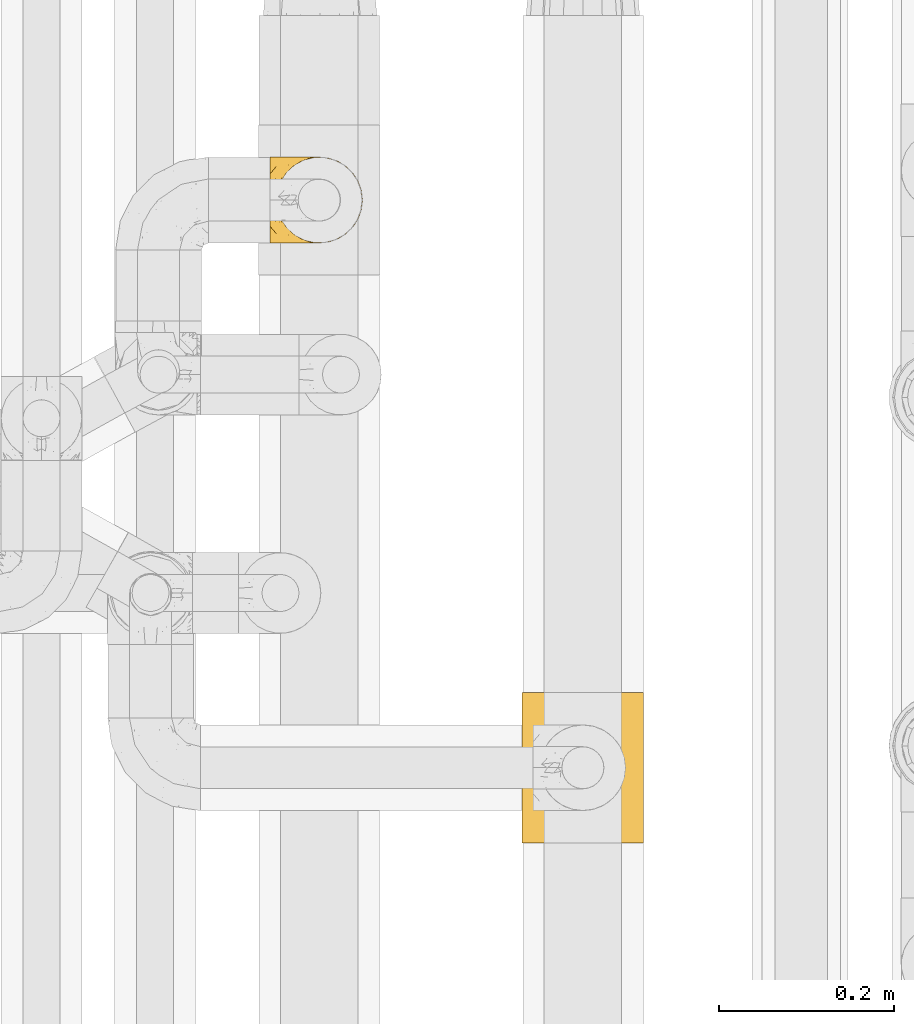
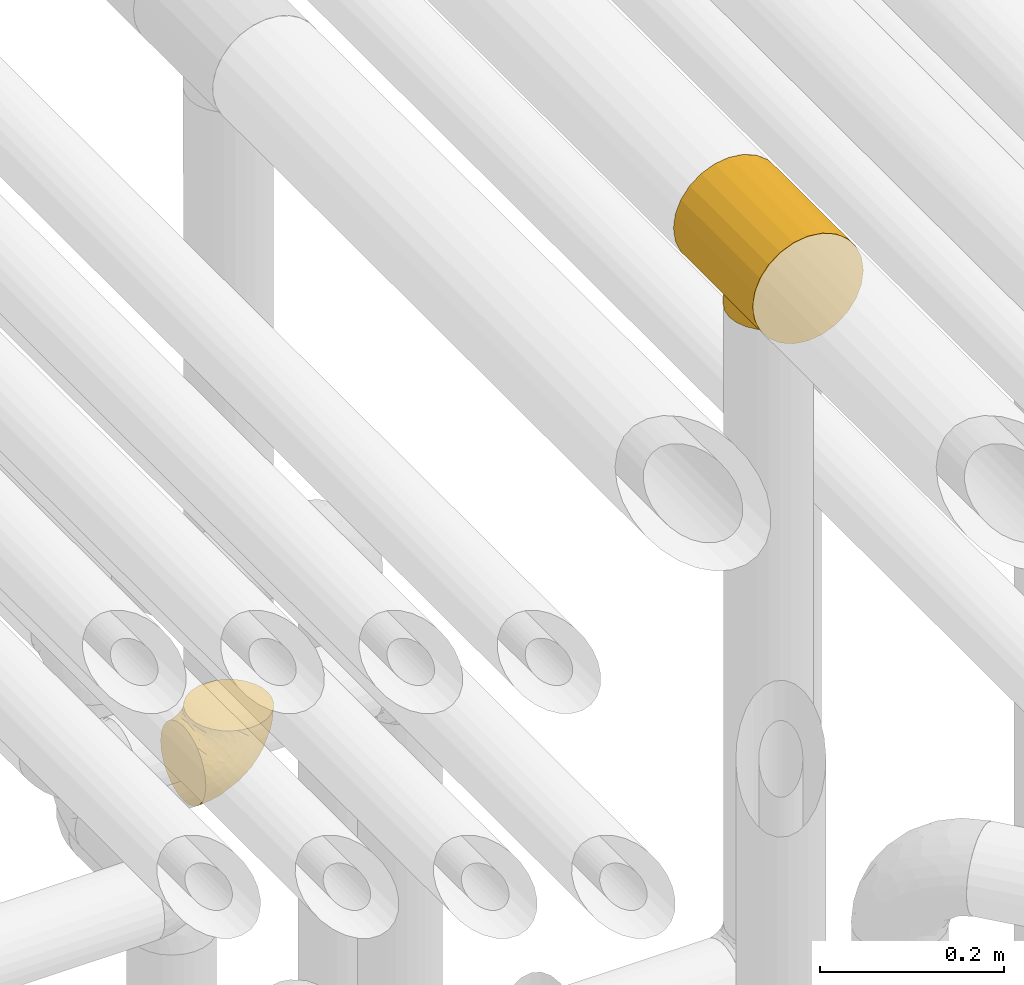
# One storey, part 222 of 827: 2 coverings.
"""IFC2X3 building model written with IfcOpenShell, lengths in millimetres."""

from ifc_helpers import new_model, entity, si_unit, converted_unit, derived_unit, direction, frame, origin, place, context, subcontext, project, spatial, faceted_brep, element, save


model = new_model("IFC2X3")

# Units and contexts
model_context = context("Model", 3, precision=0.01, world=origin(), true_north=direction((6.12303176911189e-17, 1.0)))
body_context = subcontext(model_context, "Body", "Model", "MODEL_VIEW")
ifc_project = project(units=[si_unit("LENGTHUNIT", "METRE", prefix="MILLI"), si_unit("AREAUNIT", "SQUARE_METRE"), si_unit("VOLUMEUNIT", "CUBIC_METRE"), converted_unit("PLANEANGLEUNIT", "DEGREE", entity("IfcRatioMeasure", 0.0174532925199433), si_unit("PLANEANGLEUNIT", "RADIAN"), dimensions=[0, 0, 0, 0, 0, 0, 0]), si_unit("MASSUNIT", "GRAM", prefix="KILO"), derived_unit("MASSDENSITYUNIT", [(si_unit("MASSUNIT", "GRAM", prefix="KILO"), 1), (si_unit("LENGTHUNIT", "METRE"), -3)]), derived_unit("MOMENTOFINERTIAUNIT", [(si_unit("LENGTHUNIT", "METRE"), 4)]), si_unit("TIMEUNIT", "SECOND"), si_unit("FREQUENCYUNIT", "HERTZ"), si_unit("THERMODYNAMICTEMPERATUREUNIT", "DEGREE_CELSIUS"), derived_unit("THERMALTRANSMITTANCEUNIT", [(si_unit("MASSUNIT", "GRAM", prefix="KILO"), 1), (si_unit("THERMODYNAMICTEMPERATUREUNIT", "KELVIN"), -1), (si_unit("TIMEUNIT", "SECOND"), -3)]), derived_unit("VOLUMETRICFLOWRATEUNIT", [(si_unit("LENGTHUNIT", "METRE"), 3), (si_unit("TIMEUNIT", "SECOND"), -1)]), derived_unit("MASSFLOWRATEUNIT", [(si_unit("MASSUNIT", "GRAM", prefix="KILO"), 1), (si_unit("TIMEUNIT", "SECOND"), -1)]), derived_unit("ROTATIONALFREQUENCYUNIT", [(si_unit("TIMEUNIT", "SECOND"), -1)]), si_unit("ELECTRICCURRENTUNIT", "AMPERE"), si_unit("ELECTRICVOLTAGEUNIT", "VOLT"), si_unit("POWERUNIT", "WATT"), si_unit("FORCEUNIT", "NEWTON", prefix="KILO"), si_unit("ILLUMINANCEUNIT", "LUX"), si_unit("LUMINOUSFLUXUNIT", "LUMEN"), si_unit("LUMINOUSINTENSITYUNIT", "CANDELA"), derived_unit("USERDEFINED", [(si_unit("MASSUNIT", "GRAM", prefix="KILO"), -1), (si_unit("LENGTHUNIT", "METRE"), -2), (si_unit("TIMEUNIT", "SECOND"), 3), (si_unit("LUMINOUSFLUXUNIT", "LUMEN"), 1)]), derived_unit("LINEARVELOCITYUNIT", [(si_unit("LENGTHUNIT", "METRE"), 1), (si_unit("TIMEUNIT", "SECOND"), -1)]), si_unit("PRESSUREUNIT", "PASCAL"), derived_unit("USERDEFINED", [(si_unit("LENGTHUNIT", "METRE"), -2), (si_unit("MASSUNIT", "GRAM", prefix="KILO"), 1), (si_unit("TIMEUNIT", "SECOND"), -2)]), derived_unit("LINEARFORCEUNIT", [(si_unit("MASSUNIT", "GRAM", prefix="KILO"), 1), (si_unit("LENGTHUNIT", "METRE"), 1), (si_unit("TIMEUNIT", "SECOND"), -2), (si_unit("LENGTHUNIT", "METRE"), -1)]), derived_unit("PLANARFORCEUNIT", [(si_unit("MASSUNIT", "GRAM", prefix="KILO"), 1), (si_unit("LENGTHUNIT", "METRE"), 1), (si_unit("TIMEUNIT", "SECOND"), -2), (si_unit("LENGTHUNIT", "METRE"), -2)])], contexts=[model_context])

# Site, building, storey
site_placement = place(None, origin())
site = spatial("IfcSite", under=ifc_project, at=site_placement, CompositionType="ELEMENT")
building_placement = place(site_placement, origin())
building = spatial("IfcBuilding", under=site, at=building_placement, CompositionType="ELEMENT")
storey_placement = place(building_placement, frame((0.0, 0.0, 28200.0)))
storey = spatial("IfcBuildingStorey", under=building, at=storey_placement, Name="08", CompositionType="ELEMENT", Elevation=28200.0)

# Coverings
covering_1_placement = place(storey_placement, frame((35859.94, 13155.34, 2549.25)))
element("IfcCovering", 1, at=covering_1_placement, inside=storey, Name=":ADSK_", ObjectType=":ADSK_", PredefinedType="INSULATION", context=body_context, shape_type="Brep", body=[
    faceted_brep([(58.6, 1.6, 107.78), (69.54, 2.83, 107.78), (79.93, 6.47, 107.79), (89.25, 12.32, 107.79), (97.03, 20.11, 107.8), (102.88, 29.43, 107.8), (106.51, 39.81, 107.8), (107.75, 50.75, 107.81), (106.51, 61.69, 107.8), (102.87, 72.08, 107.8), (97.02, 81.4, 107.8), (89.23, 89.18, 107.79), (79.91, 95.03, 107.79), (69.53, 98.66, 107.78), (58.6, 99.9, 107.78), (52.9, 99.25, 107.77), (47.65, 98.66, 107.77), (42.46, 96.84, 107.77), (37.26, 95.02, 107.77), (27.94, 89.17, 107.76), (20.16, 81.38, 107.76), (14.31, 72.06, 107.75), (10.68, 61.68, 107.75), (9.45, 50.75, 107.75), (10.68, 39.8, 107.75), (14.32, 29.41, 107.75), (20.17, 20.09, 107.76), (27.96, 12.31, 107.76), (37.28, 6.46, 107.77), (42.47, 4.64, 107.77), (47.66, 2.83, 107.77), (52.9, 2.24, 107.77), (55.75, 1.92, 107.78), (1.6, 63.47, 98.22), (1.6, 75.32, 93.31), (1.6, 80.41, 89.4), (1.6, 85.5, 85.5), (1.6, 89.4, 80.41), (1.6, 93.31, 75.32), (1.6, 95.77, 69.39), (1.6, 98.22, 63.47), (1.6, 99.14, 56.48), (1.6, 99.52, 53.61), (1.6, 99.9, 50.75), (1.6, 98.22, 38.02), (1.6, 93.31, 26.17), (1.6, 85.5, 15.99), (1.6, 75.32, 8.18), (1.6, 63.47, 3.27), (1.6, 50.75, 1.6), (1.6, 38.02, 3.27), (1.6, 26.17, 8.18), (1.6, 15.99, 15.99), (1.6, 8.18, 26.17), (1.6, 3.27, 38.02), (1.6, 1.6, 50.75), (1.6, 2.35, 56.48), (1.6, 3.27, 63.47), (1.6, 5.73, 69.39), (1.6, 8.18, 75.32), (1.6, 12.09, 80.41), (1.6, 15.99, 85.5), (1.6, 21.08, 89.4), (1.6, 26.17, 93.31), (1.6, 38.02, 98.22), (1.6, 50.75, 99.9), (41.53, 24.76, 17.47), (26.26, 33.81, 7.6), (51.96, 37.78, 16.29), (34.41, 50.75, 6.79), (23.38, 42.85, 4.51), (13.68, 50.75, 3.51), (69.98, 42.18, 27.54), (59.6, 28.42, 25.32), (20.19, 22.57, 12.27), (72.35, 7.18, 70.92), (65.88, 2.73, 87.2), (57.57, 3.09, 67.32), (46.52, 11.58, 33.59), (46.58, 5.17, 47.24), (23.76, 6.92, 31.65), (21.18, 2.71, 43.26), (23.42, 1.6, 55.09), (17.92, 1.6, 53.99), (12.43, 1.6, 52.9), (9.72, 1.6, 52.36), (7.01, 1.6, 51.82), (26.77, 14.18, 21.5), (76.59, 5.88, 89.97), (95.57, 41.06, 60.49), (102.58, 36.25, 83.05), (92.91, 28.63, 64.83), (54.27, 1.6, 85.95), (51.18, 1.6, 81.33), (48.09, 1.6, 76.7), (45.0, 1.6, 72.08), (41.91, 1.6, 67.45), (85.17, 10.85, 88.78), (85.99, 38.33, 46.03), (59.6, 9.6, 47.14), (99.51, 26.24, 89.45), (105.84, 50.75, 95.72), (53.6, 19.31, 28.5), (67.02, 16.41, 42.82), (71.55, 24.56, 38.27), (87.49, 50.75, 45.38), (75.75, 50.75, 33.63), (92.25, 18.48, 82.62), (58.06, 1.6, 105.07), (57.52, 1.6, 102.36), (56.44, 1.6, 96.94), (55.36, 1.6, 91.45), (81.35, 14.36, 65.96), (80.32, 20.62, 53.1), (39.45, 2.32, 54.38), (102.56, 50.75, 74.99), (37.29, 1.6, 64.36), (32.66, 1.6, 61.27), (28.04, 1.6, 58.18), (64.01, 50.75, 21.88), (74.56, 33.88, 34.82), (83.63, 29.22, 48.51), (95.03, 50.75, 60.18), (49.21, 50.75, 14.34), (46.97, 2.8, 99.1), (8.77, 2.48, 60.55), (18.29, 2.69, 64.17), (11.68, 3.2, 64.35), (11.79, 32.98, 103.17), (15.69, 24.67, 101.7), (45.86, 2.46, 89.7), (47.15, 2.49, 93.74), (40.27, 4.63, 97.49), (7.95, 17.92, 88.35), (9.27, 12.03, 82.15), (7.98, 25.72, 94.51), (13.43, 16.62, 89.64), (13.04, 25.6, 98.42), (7.37, 36.72, 99.71), (23.47, 10.65, 89.38), (30.46, 6.87, 88.23), (26.54, 11.12, 95.22), (6.76, 10.31, 79.14), (26.47, 12.84, 101.24), (20.78, 17.38, 99.42), (20.71, 9.72, 84.7), (7.15, 50.75, 102.2), (9.29, 42.52, 104.02), (38.79, 3.12, 82.67), (18.27, 17.57, 95.43), (31.81, 3.97, 78.69), (12.76, 5.94, 72.68), (22.97, 2.73, 66.46), (17.55, 6.23, 75.3), (27.64, 3.45, 72.74), (15.24, 10.83, 82.93), (33.27, 7.98, 99.28), (32.44, 7.33, 93.52), (42.5, 2.96, 87.77), (27.9, 2.39, 67.35), (7.98, 75.77, 94.51), (15.23, 90.66, 82.93), (7.94, 83.57, 88.34), (13.4, 84.86, 89.64), (15.68, 76.81, 101.69), (20.76, 84.1, 99.42), (42.5, 98.54, 87.76), (47.41, 99.3, 89.4), (51.18, 99.9, 81.33), (40.25, 96.86, 97.49), (12.43, 99.9, 52.9), (7.01, 99.9, 51.82), (4.31, 99.9, 51.28), (26.44, 88.63, 101.23), (26.53, 90.36, 95.21), (11.68, 98.29, 64.35), (12.76, 95.55, 72.68), (6.76, 91.19, 79.14), (9.27, 89.47, 82.14), (17.55, 95.26, 75.3), (33.23, 93.49, 99.29), (32.42, 94.16, 93.52), (8.77, 99.01, 60.55), (22.97, 98.76, 66.46), (18.49, 98.85, 63.97), (46.96, 98.69, 99.09), (55.36, 99.9, 91.45), (7.36, 64.78, 99.7), (17.92, 99.9, 53.99), (23.42, 99.9, 55.09), (9.29, 58.97, 104.03), (57.52, 99.9, 102.36), (56.98, 99.9, 99.65), (56.44, 99.9, 96.94), (48.09, 99.9, 76.7), (38.79, 98.37, 82.67), (13.03, 75.87, 98.42), (11.79, 68.5, 103.17), (45.0, 99.9, 72.08), (31.79, 97.52, 78.68), (30.46, 94.62, 88.22), (20.68, 91.75, 84.72), (27.64, 98.04, 72.75), (18.26, 83.91, 95.43), (23.46, 90.83, 89.38), (27.9, 99.1, 67.35), (32.66, 99.9, 61.27), (28.04, 99.9, 58.18), (54.27, 99.9, 85.95), (37.29, 99.9, 64.36), (41.91, 99.9, 67.45), (39.75, 99.09, 54.08), (23.38, 58.64, 4.51), (26.77, 87.31, 21.5), (46.19, 89.93, 33.43), (53.55, 82.21, 28.5), (41.54, 76.73, 17.47), (59.62, 73.11, 25.37), (76.8, 95.54, 90.21), (66.11, 98.7, 87.0), (21.18, 98.78, 43.26), (51.96, 63.71, 16.29), (26.26, 67.68, 7.6), (20.19, 78.92, 12.27), (23.76, 94.57, 31.65), (92.9, 72.88, 64.84), (102.58, 65.25, 83.05), (95.57, 60.44, 60.49), (71.62, 76.94, 38.35), (74.56, 67.61, 34.82), (72.53, 94.37, 71.56), (69.98, 59.31, 27.54), (92.24, 83.03, 82.62), (85.16, 90.65, 88.78), (80.43, 80.82, 53.18), (83.66, 72.23, 48.52), (57.59, 98.39, 67.3), (63.7, 92.31, 52.33), (85.98, 63.12, 45.99), (99.5, 75.26, 89.45), (81.25, 87.15, 65.8), (47.08, 96.03, 46.74), (67.01, 85.09, 42.83)], [[[0, 1, 2, 3, 4, 5, 6, 7, 8, 9, 10, 11, 12, 13, 14, 15, 16, 17, 18, 19, 20, 21, 22, 23, 24, 25, 26, 27, 28, 29, 30, 31, 32]], [[33, 34, 35, 36, 37, 38, 39, 40, 41, 42, 43, 44, 45, 46, 47, 48, 49, 50, 51, 52, 53, 54, 55, 56, 57, 58, 59, 60, 61, 62, 63, 64, 65]], [[66, 67, 68]], [[69, 70, 71]], [[72, 73, 68]], [[67, 66, 74]], [[75, 76, 77]], [[78, 79, 80]], [[67, 51, 50]], [[81, 82, 83, 84, 85, 86, 55]], [[52, 87, 53]], [[74, 52, 51]], [[2, 1, 88]], [[89, 90, 91]], [[77, 92, 93, 94, 95, 96]], [[55, 54, 81]], [[80, 53, 87]], [[5, 90, 6]], [[88, 76, 75]], [[97, 3, 2]], [[89, 91, 98]], [[99, 79, 78]], [[90, 5, 100]], [[74, 87, 52]], [[100, 5, 4]], [[90, 101, 6]], [[78, 102, 103]], [[102, 73, 104]], [[105, 98, 106]], [[107, 4, 3]], [[76, 0, 108, 109, 110, 111, 92]], [[107, 112, 113]], [[114, 77, 96]], [[89, 115, 90]], [[114, 96, 116, 117, 118, 82]], [[75, 97, 88]], [[119, 72, 68]], [[50, 71, 70]], [[100, 91, 90]], [[99, 77, 79]], [[102, 104, 103]], [[97, 107, 3]], [[79, 81, 80]], [[107, 97, 112]], [[68, 67, 70]], [[72, 98, 120]], [[80, 81, 54]], [[114, 81, 79]], [[53, 80, 54]], [[80, 87, 78]], [[102, 87, 66]], [[78, 103, 99]], [[4, 107, 100]], [[91, 100, 107]], [[88, 97, 2]], [[112, 97, 75]], [[99, 112, 75]], [[103, 104, 113]], [[91, 121, 98]], [[89, 105, 122, 115]], [[101, 90, 115]], [[101, 7, 6]], [[88, 1, 76]], [[0, 76, 1]], [[92, 77, 76]], [[67, 74, 51]], [[87, 74, 66]], [[81, 114, 82]], [[77, 114, 79]], [[87, 102, 78]], [[73, 102, 66]], [[68, 73, 66]], [[73, 120, 104]], [[120, 121, 104]], [[104, 121, 113]], [[121, 120, 98]], [[91, 107, 113]], [[91, 113, 121]], [[103, 113, 112]], [[106, 98, 72]], [[105, 89, 98]], [[106, 72, 119]], [[73, 72, 120]], [[68, 69, 123, 119]], [[50, 49, 71]], [[50, 70, 67]], [[112, 99, 103]], [[77, 99, 75]], [[69, 68, 70]], [[29, 124, 110]], [[84, 83, 125]], [[126, 82, 118]], [[59, 58, 127]], [[25, 128, 129]], [[130, 131, 132]], [[133, 62, 134]], [[135, 136, 137]], [[138, 65, 64]], [[64, 135, 138]], [[139, 140, 141]], [[111, 110, 124]], [[135, 137, 138]], [[135, 64, 63]], [[134, 61, 142]], [[125, 58, 57]], [[143, 144, 141]], [[143, 26, 144]], [[127, 83, 82]], [[28, 124, 29]], [[108, 0, 32, 31, 30, 110, 109]], [[30, 29, 110]], [[136, 145, 139]], [[132, 131, 28]], [[57, 56, 55, 86, 85, 84]], [[146, 147, 23]], [[24, 23, 147]], [[25, 144, 26]], [[95, 94, 148]], [[24, 128, 25]], [[149, 139, 144]], [[111, 131, 92]], [[127, 58, 125]], [[150, 148, 140]], [[127, 126, 151]], [[151, 59, 127]], [[152, 151, 126]], [[153, 154, 155]], [[153, 134, 142]], [[132, 28, 27]], [[111, 124, 131]], [[143, 156, 27]], [[157, 148, 158]], [[61, 134, 62]], [[135, 133, 136]], [[147, 128, 24]], [[65, 138, 146]], [[146, 138, 147]], [[128, 138, 137]], [[138, 128, 147]], [[128, 137, 129]], [[149, 129, 137]], [[25, 129, 144]], [[159, 152, 117]], [[152, 118, 117]], [[153, 151, 152]], [[159, 116, 154]], [[145, 150, 139]], [[153, 152, 159]], [[134, 153, 155]], [[134, 155, 133]], [[142, 61, 60]], [[136, 133, 155]], [[135, 63, 133]], [[145, 136, 155]], [[136, 139, 149]], [[155, 154, 145]], [[150, 154, 96]], [[154, 150, 145]], [[148, 94, 158]], [[82, 126, 127]], [[118, 152, 126]], [[150, 96, 95]], [[140, 148, 157]], [[150, 95, 148]], [[131, 130, 92]], [[158, 132, 156]], [[158, 94, 93]], [[84, 125, 57]], [[127, 125, 83]], [[141, 140, 157]], [[150, 140, 139]], [[141, 157, 143]], [[139, 141, 144]], [[156, 143, 157]], [[27, 26, 143]], [[158, 156, 157]], [[132, 27, 156]], [[133, 63, 62]], [[129, 149, 144]], [[136, 149, 137]], [[60, 151, 142]], [[59, 151, 60]], [[142, 151, 153]], [[28, 131, 124]], [[132, 158, 130]], [[158, 93, 130]], [[92, 130, 93]], [[116, 96, 154]], [[153, 159, 154]], [[159, 117, 116]], [[34, 33, 160]], [[161, 162, 163]], [[164, 21, 165]], [[166, 167, 168]], [[19, 18, 169]], [[165, 21, 20]], [[42, 41, 40, 170, 171, 172, 43]], [[173, 174, 165]], [[175, 38, 176]], [[177, 178, 179]], [[180, 166, 181]], [[40, 182, 170]], [[183, 184, 176]], [[185, 17, 186]], [[65, 146, 187]], [[188, 175, 189]], [[23, 22, 190]], [[175, 39, 38]], [[15, 14, 191, 192, 193, 16]], [[182, 40, 39]], [[194, 195, 166]], [[164, 196, 197]], [[33, 187, 160]], [[181, 174, 173]], [[198, 199, 195]], [[18, 185, 169]], [[174, 181, 200]], [[201, 199, 202]], [[193, 186, 17]], [[193, 17, 16]], [[18, 17, 185]], [[196, 160, 187]], [[203, 165, 204]], [[187, 190, 197]], [[205, 206, 183]], [[188, 182, 175]], [[161, 179, 178]], [[207, 184, 183]], [[207, 183, 206]], [[186, 208, 185]], [[208, 167, 185]], [[167, 166, 169]], [[173, 180, 181]], [[196, 203, 163]], [[178, 162, 161]], [[65, 187, 33]], [[190, 146, 23]], [[197, 190, 22]], [[187, 146, 190]], [[21, 197, 22]], [[187, 197, 196]], [[21, 164, 197]], [[203, 164, 165]], [[176, 179, 183]], [[175, 184, 189]], [[179, 202, 205]], [[201, 161, 163]], [[202, 209, 205]], [[176, 38, 37]], [[202, 179, 161]], [[177, 179, 176]], [[178, 35, 162]], [[34, 160, 162]], [[163, 162, 160]], [[196, 163, 160]], [[201, 163, 204]], [[199, 201, 204]], [[202, 161, 201]], [[195, 200, 181]], [[202, 199, 210]], [[189, 184, 207]], [[176, 184, 175]], [[195, 194, 198]], [[198, 210, 199]], [[200, 199, 204]], [[181, 166, 195]], [[175, 182, 39]], [[168, 167, 208]], [[168, 194, 166]], [[170, 182, 188]], [[199, 200, 195]], [[174, 204, 165]], [[204, 174, 200]], [[173, 165, 20]], [[20, 19, 173]], [[180, 173, 19]], [[19, 169, 180]], [[166, 180, 169]], [[35, 178, 36]], [[35, 34, 162]], [[185, 167, 169]], [[163, 203, 204]], [[164, 203, 196]], [[36, 178, 177]], [[37, 177, 176]], [[37, 36, 177]], [[179, 205, 183]], [[209, 202, 210]], [[209, 206, 205]], [[211, 189, 207, 206, 209, 210]], [[48, 212, 71]], [[213, 214, 215]], [[216, 215, 217]], [[218, 219, 13]], [[220, 43, 172, 171, 170, 188, 189]], [[221, 222, 216]], [[47, 46, 223]], [[212, 48, 222]], [[213, 224, 214]], [[224, 45, 44]], [[223, 222, 47]], [[47, 222, 48]], [[223, 213, 216]], [[225, 226, 227]], [[213, 46, 45]], [[228, 229, 217]], [[43, 220, 44]], [[219, 218, 230]], [[217, 231, 221]], [[14, 13, 219]], [[226, 9, 8]], [[10, 232, 11]], [[11, 233, 12]], [[234, 225, 235]], [[236, 210, 198, 194, 168, 208]], [[237, 236, 230]], [[224, 44, 220]], [[106, 231, 238]], [[226, 239, 9]], [[233, 240, 230]], [[9, 239, 10]], [[115, 226, 101]], [[241, 236, 237]], [[233, 11, 232]], [[225, 232, 239]], [[226, 8, 101]], [[225, 238, 235]], [[227, 115, 122, 105]], [[218, 12, 233]], [[211, 236, 241]], [[212, 221, 69]], [[221, 216, 217]], [[231, 119, 221]], [[211, 220, 189]], [[241, 214, 224]], [[241, 224, 220]], [[45, 224, 213]], [[237, 214, 241]], [[215, 214, 242]], [[225, 239, 226]], [[232, 10, 239]], [[240, 233, 232]], [[218, 233, 230]], [[234, 232, 225]], [[237, 240, 242]], [[115, 227, 226]], [[235, 238, 229]], [[8, 7, 101]], [[236, 211, 210]], [[220, 211, 241]], [[219, 230, 236]], [[13, 12, 218]], [[236, 208, 219]], [[219, 208, 186, 193, 192, 191, 14]], [[213, 223, 46]], [[222, 223, 216]], [[71, 212, 69]], [[71, 49, 48]], [[221, 212, 222]], [[228, 217, 215]], [[213, 215, 216]], [[228, 215, 242]], [[217, 229, 231]], [[234, 242, 240]], [[235, 229, 228]], [[234, 235, 228]], [[238, 225, 227]], [[242, 234, 228]], [[234, 240, 232]], [[227, 105, 238]], [[238, 105, 106]], [[231, 106, 119]], [[69, 221, 119, 123]], [[238, 231, 229]], [[240, 237, 230]], [[214, 237, 242]]]),
])
covering_2_placement = place(storey_placement, frame((36148.99, 12470.08, 3477.0)))
element("IfcCovering", 2, at=covering_2_placement, inside=storey, Name=":ADSK_", ObjectType=":ADSK_", PredefinedType="INSULATION", context=body_context, shape_type="Brep", body=[
    faceted_brep([(3.96, 172.0, 90.97), (10.9, 172.0, 107.72), (21.94, 172.0, 122.11), (36.32, 172.0, 133.15), (53.07, 172.0, 140.08), (71.05, 172.0, 142.45), (89.02, 172.0, 140.08), (105.77, 172.0, 133.15), (120.15, 172.0, 122.11), (131.19, 172.0, 107.72), (138.13, 172.0, 90.97), (140.5, 172.0, 73.0), (138.13, 172.0, 55.03), (131.19, 172.0, 38.27), (120.15, 172.0, 23.89), (105.77, 172.0, 12.85), (97.4, 172.0, 9.39), (89.02, 172.0, 5.92), (80.03, 172.0, 4.73), (71.05, 172.0, 3.55), (62.06, 172.0, 4.73), (53.07, 172.0, 5.92), (44.7, 172.0, 9.39), (36.32, 172.0, 12.85), (21.94, 172.0, 23.89), (10.9, 172.0, 38.27), (3.96, 172.0, 55.03), (1.6, 172.0, 73.0), (120.15, 0.0, 122.11), (105.77, 0.0, 133.15), (89.02, 0.0, 140.08), (71.05, 0.0, 142.45), (53.07, 0.0, 140.08), (36.32, 0.0, 133.15), (21.94, 0.0, 122.11), (10.9, 0.0, 107.73), (3.96, 0.0, 90.97), (1.6, 0.0, 73.0), (3.96, 0.0, 55.03), (10.9, 0.0, 38.28), (21.94, 0.0, 23.89), (36.32, 0.0, 12.85), (44.7, 0.0, 9.39), (53.07, 0.0, 5.92), (62.06, 0.0, 4.73), (71.05, 0.0, 3.55), (80.03, 0.0, 4.73), (89.02, 0.0, 5.92), (97.4, 0.0, 9.39), (105.77, 0.0, 12.85), (120.15, 0.0, 23.89), (131.19, 0.0, 38.28), (138.13, 0.0, 55.03), (140.5, 0.0, 73.0), (138.13, 0.0, 90.97), (131.19, 0.0, 107.73), (109.48, 55.36, 15.15), (115.18, 64.37, 19.38), (92.88, 130.03, 7.07), (118.88, 74.72, 22.65), (82.39, 38.18, 4.48), (120.2, 86.0, 23.93), (118.88, 97.28, 22.65), (82.39, 133.82, 4.48), (76.72, 134.49, 4.02), (71.05, 135.15, 3.55), (109.48, 116.64, 15.15), (115.18, 107.63, 19.38), (102.0, 47.82, 10.83), (92.88, 41.97, 7.07), (71.05, 36.85, 3.55), (76.72, 37.51, 4.02), (87.64, 40.07, 5.78), (102.0, 124.18, 10.83), (87.64, 131.93, 5.78), (59.7, 38.18, 4.48), (40.09, 47.82, 10.83), (49.21, 41.97, 7.07), (54.46, 40.07, 5.78), (65.38, 134.49, 4.02), (59.7, 133.82, 4.48), (40.09, 124.18, 10.83), (49.21, 130.03, 7.07), (32.61, 116.64, 15.15), (54.46, 131.93, 5.78), (32.61, 55.36, 15.15), (26.91, 64.37, 19.38), (23.21, 74.72, 22.65), (65.38, 37.51, 4.02), (21.9, 86.0, 23.93), (26.91, 107.63, 19.38), (23.21, 97.28, 22.65), (95.62, 43.43, 0.0), (89.69, 40.98, 0.0), (83.77, 38.52, 0.0), (77.41, 37.69, 0.0), (71.05, 36.85, 0.0), (64.68, 37.69, 0.0), (58.32, 38.52, 0.0), (52.4, 40.98, 0.0), (46.47, 43.43, 0.0), (36.29, 51.25, 0.0), (28.48, 61.42, 0.0), (23.57, 73.28, 0.0), (21.9, 86.0, 0.0), (23.57, 98.72, 0.0), (28.48, 110.57, 0.0), (36.29, 120.75, 0.0), (46.47, 128.57, 0.0), (52.4, 131.02, 0.0), (58.32, 133.48, 0.0), (64.68, 134.31, 0.0), (71.05, 135.15, 0.0), (77.41, 134.31, 0.0), (83.77, 133.48, 0.0), (89.69, 131.02, 0.0), (95.62, 128.57, 0.0), (105.8, 120.75, 0.0), (113.61, 110.57, 0.0), (118.52, 98.72, 0.0), (120.2, 86.0, 0.0), (118.52, 73.28, 0.0), (113.61, 61.42, 0.0), (105.8, 51.25, 0.0)], [[[0, 1, 2, 3, 4, 5, 6, 7, 8, 9, 10, 11, 12, 13, 14, 15, 16, 17, 18, 19, 20, 21, 22, 23, 24, 25, 26, 27]], [[28, 29, 30, 31, 32, 33, 34, 35, 36, 37, 38, 39, 40, 41, 42, 43, 44, 45, 46, 47, 48, 49, 50, 51, 52, 53, 54, 55]], [[29, 28, 8, 7]], [[5, 31, 30, 6]], [[7, 6, 30, 29]], [[9, 55, 54, 10]], [[10, 54, 53, 11]], [[8, 28, 55, 9]], [[52, 12, 11, 53]], [[51, 13, 12, 52]], [[50, 56, 57]], [[56, 50, 49]], [[58, 17, 16]], [[57, 59, 50]], [[60, 47, 46]], [[51, 50, 61]], [[50, 59, 61]], [[61, 62, 14]], [[18, 63, 64, 65]], [[66, 14, 67]], [[67, 14, 62]], [[68, 48, 69]], [[61, 14, 13]], [[61, 13, 51]], [[48, 68, 49]], [[69, 48, 47]], [[45, 70, 46]], [[65, 19, 18]], [[46, 70, 71, 60]], [[47, 60, 72, 69]], [[66, 73, 15]], [[73, 16, 15]], [[16, 73, 58]], [[66, 15, 14]], [[18, 17, 63]], [[17, 58, 74, 63]], [[68, 56, 49]], [[45, 44, 70]], [[65, 20, 19]], [[75, 44, 43]], [[41, 76, 42]], [[77, 42, 76]], [[43, 77, 78, 75]], [[20, 65, 79, 80]], [[81, 23, 22]], [[22, 21, 82]], [[23, 81, 83]], [[21, 80, 84, 82]], [[85, 76, 41]], [[86, 85, 40]], [[87, 86, 40]], [[44, 75, 88, 70]], [[39, 38, 26, 25]], [[89, 40, 39]], [[87, 40, 89]], [[85, 41, 40]], [[26, 38, 37, 27]], [[90, 91, 24]], [[80, 21, 20]], [[83, 24, 23]], [[24, 83, 90]], [[91, 89, 24]], [[77, 43, 42]], [[89, 25, 24]], [[89, 39, 25]], [[81, 22, 82]], [[0, 36, 35, 1]], [[1, 35, 34, 2]], [[37, 36, 0, 27]], [[3, 33, 32, 4]], [[4, 32, 31, 5]], [[2, 34, 33, 3]], [[92, 93, 94, 95, 96, 97, 98, 99, 100, 101, 102, 103, 104, 105, 106, 107, 108, 109, 110, 111, 112, 113, 114, 115, 116, 117, 118, 119, 120, 121, 122, 123]], [[60, 95, 94]], [[69, 93, 92]], [[96, 71, 70]], [[96, 95, 71]], [[94, 72, 60]], [[68, 69, 92]], [[93, 72, 94]], [[95, 60, 71]], [[92, 123, 68]], [[56, 123, 122]], [[121, 120, 59]], [[57, 122, 121]], [[93, 69, 72]], [[56, 122, 57]], [[59, 57, 121]], [[61, 59, 120]], [[123, 56, 68]], [[62, 120, 119]], [[67, 119, 118]], [[61, 120, 62]], [[112, 64, 113]], [[62, 119, 67]], [[118, 66, 67]], [[118, 117, 66]], [[73, 117, 116]], [[63, 74, 114]], [[64, 112, 65]], [[63, 114, 113]], [[58, 73, 116]], [[58, 116, 115]], [[63, 113, 64]], [[115, 74, 58]], [[114, 74, 115]], [[117, 73, 66]], [[80, 111, 110]], [[82, 109, 108]], [[112, 79, 65]], [[112, 111, 79]], [[110, 84, 80]], [[81, 82, 108]], [[109, 84, 110]], [[111, 80, 79]], [[108, 107, 81]], [[83, 107, 106]], [[106, 105, 90]], [[104, 91, 105]], [[109, 82, 84]], [[83, 106, 90]], [[91, 90, 105]], [[89, 91, 104]], [[107, 83, 81]], [[87, 104, 103]], [[86, 103, 102]], [[89, 104, 87]], [[96, 88, 97]], [[87, 103, 86]], [[102, 85, 86]], [[102, 101, 85]], [[76, 101, 100]], [[75, 78, 98]], [[88, 96, 70]], [[75, 98, 97]], [[77, 76, 100]], [[77, 100, 99]], [[75, 97, 88]], [[99, 78, 77]], [[98, 78, 99]], [[101, 76, 85]]]),
])

save(model, "model.ifc")
